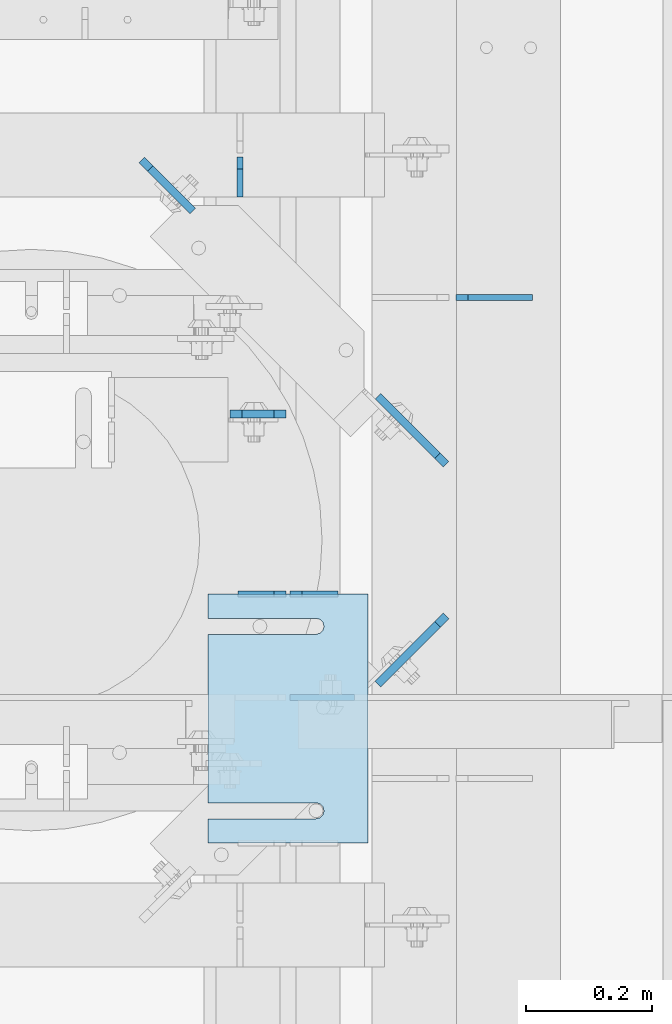
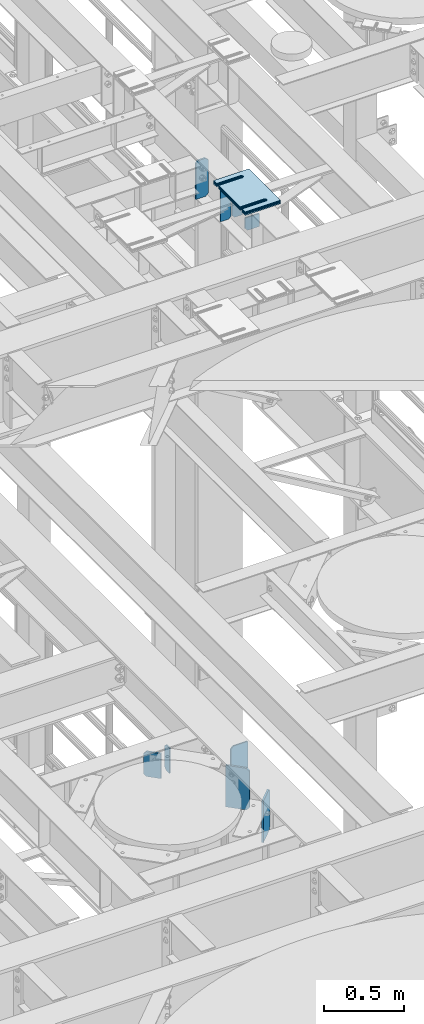
# One storey, part 1639 of 1876: 15 plates, 9 elements without a shape of their own.
"""IFC2X3 building model written with IfcOpenShell, lengths in millimetres."""

from ifc_helpers import new_model, si_unit, frame, origin_with_axes, place, context, subcontext, project, spatial, faceted_brep, material, type_object, element, aggregate, save


model = new_model("IFC2X3")

# Units and contexts
model_context = context("Model", 3, precision=1e-05, world=origin_with_axes())
body_context = subcontext(model_context, "Body", "Model", "MODEL_VIEW")
ifc_project = project(units=[si_unit("LENGTHUNIT", "METRE", prefix="MILLI"), si_unit("AREAUNIT", "SQUARE_METRE"), si_unit("VOLUMEUNIT", "CUBIC_METRE"), si_unit("MASSUNIT", "GRAM", prefix="KILO"), si_unit("TIMEUNIT", "SECOND"), si_unit("PLANEANGLEUNIT", "RADIAN"), si_unit("SOLIDANGLEUNIT", "STERADIAN"), si_unit("THERMODYNAMICTEMPERATUREUNIT", "DEGREE_CELSIUS"), si_unit("LUMINOUSINTENSITYUNIT", "LUMEN")], contexts=[model_context])

# Site, building, storey
site_placement = place(None, origin_with_axes())
site = spatial("IfcSite", under=ifc_project, at=site_placement, CompositionType="ELEMENT")
building_placement = place(site_placement, origin_with_axes())
building = spatial("IfcBuilding", under=site, at=building_placement, Name="Undefined", CompositionType="ELEMENT")
storey_placement = place(building_placement, origin_with_axes())
storey = spatial("IfcBuildingStorey", under=building, at=storey_placement, Name="Undefined", CompositionType="ELEMENT", Elevation=0.0)

# Assembly, plates
assembly_1_placement = place(storey_placement, origin_with_axes())
assembly_1 = element("IfcElementAssembly", 1, at=assembly_1_placement, inside=storey, Name="BEAM", AssemblyPlace="NOTDEFINED", PredefinedType="RIGID_FRAME")
ifc_material = material(Name="STEEL/A36")
plate_type_1 = type_object("IfcPlateType", PredefinedType="NOTDEFINED")
plate_1_placement = place(assembly_1_placement, frame((4905.375, 2355.85161899327, 17681.575), z_axis=(0.0, 0.0, 1.0), x_axis=(-1.0, 0.0, 0.0)))
plate_1 = element("IfcPlate", 2, at=plate_1_placement, type_object=plate_type_1, material=ifc_material, Name="PLATE", context=body_context, shape_type="Brep", body=[
    faceted_brep([(0.0, -4.76249999999982, 0.0), (0.0, -4.76249999999982, 292.100006103516), (0.0, 4.76249999999982, 292.100006103516), (0.0, 4.76249999999982, 0.0), (57.1499977111816, -4.76249999999982, 292.100006103516), (57.1499977111816, 4.76249999999982, 292.100006103516), (76.1999969482422, -4.76249999999982, 273.050006866455), (76.1999969482422, 4.76249999999982, 273.050006866455), (76.1999969482422, -4.76249999999982, 19.0499992370605), (76.1999969482422, 4.76249999999982, 19.0499992370605), (57.1499977111816, -4.76249999999982, 0.0), (57.1499977111816, 4.76249999999982, 0.0)], [[[0, 1, 2, 3]], [[1, 4, 5, 2]], [[4, 6, 7, 5]], [[6, 8, 9, 7]], [[8, 10, 11, 9]], [[10, 0, 3, 11]], [[5, 7, 9, 11, 3, 2]], [[10, 8, 6, 4, 1, 0]]]),
])
plate_2_placement = place(assembly_1_placement, frame((4822.825, 2355.85161899327, 17681.575), z_axis=(0.0, 0.0, 1.0), x_axis=(-1.0, 0.0, 0.0)))
plate_2 = element("IfcPlate", 3, at=plate_2_placement, type_object=plate_type_1, material=ifc_material, Name="PLATE", context=body_context, shape_type="Brep", body=[
    faceted_brep([(0.0, -4.76249999999982, 19.0499992370605), (0.0, -4.76249999999982, 273.050006866455), (0.0, 4.76249999999982, 273.050006866455), (0.0, 4.76249999999982, 19.0499992370605), (19.0499992370605, -4.76249999999982, 292.100006103516), (19.0499992370605, 4.76249999999982, 292.100006103516), (76.1999969482422, -4.76249999999982, 292.100006103516), (76.1999969482422, 4.76249999999982, 292.100006103516), (76.1999969482422, -4.76250000000073, 0.0), (76.1999969482422, 4.76250000000073, 0.0), (19.0499992370605, -4.76249999999982, 0.0), (19.0499992370605, 4.76249999999982, 0.0)], [[[0, 1, 2, 3]], [[1, 4, 5, 2]], [[4, 6, 7, 5]], [[6, 8, 9, 7]], [[8, 10, 11, 9]], [[10, 0, 3, 11]], [[5, 7, 9, 11, 3, 2]], [[10, 8, 6, 4, 1, 0]]]),
])

# Assembly, plate
assembly_2_placement = place(storey_placement, origin_with_axes())
assembly_2 = element("IfcElementAssembly", 4, at=assembly_2_placement, inside=storey, Name="BEAM", AssemblyPlace="NOTDEFINED", PredefinedType="RIGID_FRAME")
plate_type_2 = type_object("IfcPlateType", PredefinedType="NOTDEFINED")
plate_3_placement = place(assembly_2_placement, frame((4749.8, 2984.5, 13111.1625), z_axis=(0.0, 0.0, 1.0), x_axis=(0.0, 1.0, 0.0)))
plate_3 = element("IfcPlate", 5, at=plate_3_placement, type_object=plate_type_2, material=ifc_material, Name="PLATE", context=body_context, shape_type="Brep", body=[
    faceted_brep([(0.0, -4.76249999999982, 0.0), (0.0, -4.76249999999982, 190.5), (0.0, 4.76249999999982, 190.5), (0.0, 4.76249999999982, 0.0), (44.4500007629395, -4.76249999999982, 190.5), (44.4500007629395, 4.76249999999982, 190.5), (63.5, -4.76249999999982, 171.450000762939), (63.5, 4.76249999999982, 171.450000762939), (63.5, -4.76249999999982, 19.0499992370605), (63.5, 4.76249999999982, 19.0499992370605), (44.4500007629395, -4.76249999999982, 0.0), (44.4500007629395, 4.76249999999982, 0.0)], [[[0, 1, 2, 3]], [[1, 4, 5, 2]], [[4, 6, 7, 5]], [[6, 8, 9, 7]], [[8, 10, 11, 9]], [[10, 0, 3, 11]], [[5, 7, 9, 11, 3, 2]], [[10, 8, 6, 4, 1, 0]]]),
])

# Plate
plate_type_3 = type_object("IfcPlateType", PredefinedType="NOTDEFINED")
plate_4_placement = place(assembly_1_placement, frame((4829.17444174189, 2192.33987259546, 17780.0934066252), z_axis=(1.0, 0.0, 0.0), x_axis=(0.0, 0.0, -1.0)))
plate_4 = element("IfcPlate", 6, at=plate_4_placement, type_object=plate_type_3, material=ifc_material, Name="PLATE", context=body_context, shape_type="Brep", body=[
    faceted_brep([(0.0, -4.76249999999982, 0.0), (0.0, -4.76250000001255, 102.325820922852), (0.0, 4.76249999998754, 102.325820922853), (0.0, 4.76249999999982, 0.0), (98.5184097290039, -4.76250000001255, 102.325820922852), (98.5184097290039, 4.76249999998754, 102.325820922853), (98.5184097290039, -4.76250000000164, 19.0499992370587), (98.5184097290039, 4.76249999999845, 19.0499992370605), (79.4684104919434, -4.76249999999936, -9.09494701772928e-13), (79.4684104919434, 4.76250000000027, 0.0)], [[[0, 1, 2, 3]], [[1, 4, 5, 2]], [[4, 6, 7, 5]], [[6, 8, 9, 7]], [[8, 0, 3, 9]], [[5, 7, 9, 3, 2]], [[8, 6, 4, 1, 0]]]),
])

plate_type_4 = type_object("IfcPlateType", PredefinedType="NOTDEFINED")
plate_5_placement = place(assembly_1_placement, frame((4822.825, 2641.59941415787, 17683.1625), z_axis=(0.0, 0.0, 1.0), x_axis=(-1.0, 0.0, 0.0)))
plate_5 = element("IfcPlate", 7, at=plate_5_placement, type_object=plate_type_4, material=ifc_material, Name="PLATE", context=body_context, shape_type="Brep", body=[
    faceted_brep([(0.0, -6.35000000000196, 19.0499992370605), (0.0, -6.35000000000036, 271.462512969971), (0.0, 6.35000000000036, 271.462512969971), (0.0, 6.35000000000105, 19.0499992370605), (19.0499992370605, -6.35000000000036, 290.512512207031), (19.0499992370605, 6.35000000000036, 290.512512207031), (69.8500003814697, -6.34999999999991, 290.512512207031), (69.8500003814697, 6.34999999999991, 290.512512207031), (88.9000015258789, -6.35000000000036, 271.462512969971), (88.9000015258789, 6.35000000000036, 271.462512969971), (88.9000015258789, -6.34999999999991, 0.0), (88.9000015258789, 6.34999999999991, 0.0), (19.0499992370642, -6.35000000000105, 0.0), (19.0499992370633, 6.35000000000105, 0.0)], [[[0, 1, 2, 3]], [[1, 4, 5, 2]], [[4, 6, 7, 5]], [[6, 8, 9, 7]], [[8, 10, 11, 9]], [[10, 12, 13, 11]], [[12, 0, 3, 13]], [[5, 7, 9, 11, 13, 3, 2]], [[12, 10, 8, 6, 4, 1, 0]]]),
])

aggregate(assembly_1, [plate_1, plate_2, plate_4, plate_5])

# Assembly, plate
assembly_3_placement = place(storey_placement, origin_with_axes())
assembly_3 = element("IfcElementAssembly", 8, at=assembly_3_placement, inside=storey, Name="SHIM PLATE", AssemblyPlace="NOTDEFINED", PredefinedType="RIGID_FRAME")
plate_type_5 = type_object("IfcPlateType", PredefinedType="NOTDEFINED")
plate_6_placement = place(assembly_3_placement, frame((4952.99891175895, 1962.15311651737, 18007.0115), z_axis=(-1.0, 0.0, 0.0), x_axis=(0.0, 1.0, 0.0)))
plate_6 = element("IfcPlate", 9, at=plate_6_placement, type_object=plate_type_5, material=ifc_material, Name="SHIM PLATE", context=body_context, shape_type="Brep", body=[
    faceted_brep([(38.0954210666328, -1.58750000000146, 253.999557495103), (38.0976431969724, -1.58750000000146, 82.6182312417654), (38.0976431969724, 1.58750000000146, 82.6182312417654), (38.0954210666328, 1.58750000000146, 253.999557495103), (39.7991131045027, -1.58750000000146, 76.2682279470096), (39.7991131045027, 1.58750000000146, 76.2682279470096), (44.4476316136985, -1.58750000000146, 71.6196994315187), (44.4476316136985, 1.58750000000146, 71.6196994315187), (50.7976312458977, -1.58750000000146, 69.9182158551362), (50.7976312458977, 1.58750000000146, 69.9182158551362), (57.1476337740625, -1.58750000000146, 71.6196886236189), (57.1476337740625, 1.58750000000146, 71.6196886236189), (61.7961601951824, -1.58750000000146, 76.2682092271793), (61.7961601951824, 1.58750000000146, 76.2682092271793), (63.497640910601, -1.58750000000146, 82.6182096259718), (63.497640910601, 1.58750000000146, 82.6182096259718), (63.4954187799489, -1.58750000000146, 253.999557267866), (63.4954187799489, 1.58750000000146, 253.999557495093), (9.09494701772928e-13, -1.58750000000146, 4.54747350886464e-13), (1.89071320164658e-05, -1.58750000000146, 253.999557495117), (1.89071320164658e-05, 1.58750000000146, 253.999557495117), (9.09494701772928e-13, 1.58750000000146, 4.54747350886464e-13), (393.698486328125, -1.58750000000146, -1.40062184073031e-10), (393.698486328125, 1.58750000000146, -1.40062184073031e-10), (393.698516845714, -1.58750000000146, 253.999557494967), (393.698516845714, 1.58750000000146, 253.999557494967), (355.593905292273, 1.58750000000146, 253.999557494981), (355.593905292273, -1.58750000000146, 253.999558194833), (355.596127251301, 1.58750000000146, 82.6182258117283), (355.596127251301, -1.58750000000146, 82.6182258117283), (353.894652887411, 1.58750000000146, 76.2682211679371), (353.894652887411, -1.58750000000146, 76.2682211679371), (349.246128913514, 1.58750000000146, 71.6196946431969), (349.246128913514, -1.58750000000146, 71.6196946431969), (342.896125203397, 1.58750000000146, 69.9182167947934), (342.896125203397, -1.58750000000146, 69.9182167947934), (336.546122348359, 1.58750000000146, 71.6196978343955), (336.546122348359, -1.58750000000146, 71.6196978343955), (331.897600710579, 1.58750000000146, 76.2682266952543), (331.897600710579, -1.58750000000146, 76.2682266952543), (330.196129537885, 1.58750000000146, 82.6182321941214), (330.196129537885, -1.58750000000146, 82.6182321941214), (330.193907578964, -1.58750000000146, 253.999557494991), (330.193907578964, 1.58750000000146, 253.999557494991)], [[[0, 1, 2, 3]], [[4, 5, 2, 1]], [[6, 7, 5, 4]], [[8, 9, 7, 6]], [[10, 11, 9, 8]], [[12, 13, 11, 10]], [[14, 15, 13, 12]], [[16, 17, 15, 14]], [[18, 19, 20, 21]], [[22, 18, 21, 23]], [[24, 22, 23, 25]], [[24, 25, 26, 27]], [[27, 26, 28, 29]], [[29, 28, 30, 31]], [[31, 30, 32, 33]], [[33, 32, 34, 35]], [[35, 34, 36, 37]], [[37, 36, 38, 39]], [[39, 38, 40, 41]], [[42, 41, 40, 43]], [[12, 10, 8, 6, 4, 1, 0, 19, 18, 22, 24, 27, 29, 31, 33, 35, 37, 39, 41, 42, 16, 14]], [[20, 19, 0, 3]], [[43, 40, 38, 36, 34, 32, 30, 28, 26, 25, 23, 21, 20, 3, 2, 5, 7, 9, 11, 13, 15, 17]], [[42, 43, 17, 16]]]),
])
aggregate(assembly_3, [plate_6])

assembly_4_placement = place(storey_placement, origin_with_axes())
assembly_4 = element("IfcElementAssembly", 10, at=assembly_4_placement, inside=storey, Name="SHIM PLATE", AssemblyPlace="NOTDEFINED", PredefinedType="RIGID_FRAME")
plate_7_placement = place(assembly_4_placement, frame((4952.99891175913, 1962.15311651737, 18003.8365), z_axis=(-1.0, 0.0, 0.0), x_axis=(0.0, 1.0, 0.0)))
plate_7 = element("IfcPlate", 11, at=plate_7_placement, type_object=plate_type_5, material=ifc_material, Name="SHIM PLATE", context=body_context, shape_type="Brep", body=[
    faceted_brep([(38.0954210666328, -1.58750000000146, 253.999557495103), (38.0976431969724, -1.58750000000146, 82.6182312417654), (38.0976431969724, 1.58750000000146, 82.6182312417654), (38.0954210666328, 1.58750000000146, 253.999557495103), (39.7991131045027, -1.58750000000146, 76.2682279470096), (39.7991131045027, 1.58750000000146, 76.2682279470096), (44.4476316136985, -1.58750000000146, 71.6196994315187), (44.4476316136985, 1.58750000000146, 71.6196994315187), (50.7976312458977, -1.58750000000146, 69.9182158551362), (50.7976312458977, 1.58750000000146, 69.9182158551362), (57.1476337740625, -1.58750000000146, 71.6196886236189), (57.1476337740625, 1.58750000000146, 71.6196886236189), (61.7961601951824, -1.58750000000146, 76.2682092271793), (61.7961601951824, 1.58750000000146, 76.2682092271793), (63.497640910601, -1.58750000000146, 82.6182096259718), (63.497640910601, 1.58750000000146, 82.6182096259718), (63.4954187799489, -1.58750000000146, 253.999557267866), (63.4954187799489, 1.58750000000146, 253.999557495093), (9.09494701772928e-13, -1.58750000000146, 4.54747350886464e-13), (1.89071320164658e-05, -1.58750000000146, 253.999557495117), (1.89071320164658e-05, 1.58750000000146, 253.999557495117), (9.09494701772928e-13, 1.58750000000146, 4.54747350886464e-13), (393.698486328125, -1.58750000000146, -1.40062184073031e-10), (393.698486328125, 1.58750000000146, -1.40062184073031e-10), (393.698516845714, -1.58750000000146, 253.999557494967), (393.698516845714, 1.58750000000146, 253.999557494967), (355.593905292273, 1.58750000000146, 253.999557494981), (355.593905292273, -1.58750000000146, 253.999558194833), (355.596127251301, 1.58750000000146, 82.6182258117283), (355.596127251301, -1.58750000000146, 82.6182258117283), (353.894652887411, 1.58750000000146, 76.2682211679371), (353.894652887411, -1.58750000000146, 76.2682211679371), (349.246128913514, 1.58750000000146, 71.6196946431969), (349.246128913514, -1.58750000000146, 71.6196946431969), (342.896125203397, 1.58750000000146, 69.9182167947934), (342.896125203397, -1.58750000000146, 69.9182167947934), (336.546122348359, 1.58750000000146, 71.6196978343955), (336.546122348359, -1.58750000000146, 71.6196978343955), (331.897600710579, 1.58750000000146, 76.2682266952543), (331.897600710579, -1.58750000000146, 76.2682266952543), (330.196129537885, 1.58750000000146, 82.6182321941214), (330.196129537885, -1.58750000000146, 82.6182321941214), (330.193907578964, -1.58750000000146, 253.999557494991), (330.193907578964, 1.58750000000146, 253.999557494991)], [[[0, 1, 2, 3]], [[4, 5, 2, 1]], [[6, 7, 5, 4]], [[8, 9, 7, 6]], [[10, 11, 9, 8]], [[12, 13, 11, 10]], [[14, 15, 13, 12]], [[16, 17, 15, 14]], [[18, 19, 20, 21]], [[22, 18, 21, 23]], [[24, 22, 23, 25]], [[24, 25, 26, 27]], [[27, 26, 28, 29]], [[29, 28, 30, 31]], [[31, 30, 32, 33]], [[33, 32, 34, 35]], [[35, 34, 36, 37]], [[37, 36, 38, 39]], [[39, 38, 40, 41]], [[42, 41, 40, 43]], [[12, 10, 8, 6, 4, 1, 0, 19, 18, 22, 24, 27, 29, 31, 33, 35, 37, 39, 41, 42, 16, 14]], [[20, 19, 0, 3]], [[43, 40, 38, 36, 34, 32, 30, 28, 26, 25, 23, 21, 20, 3, 2, 5, 7, 9, 11, 13, 15, 17]], [[42, 43, 17, 16]]]),
])
aggregate(assembly_4, [plate_7])

assembly_5_placement = place(storey_placement, origin_with_axes())
assembly_5 = element("IfcElementAssembly", 12, at=assembly_5_placement, inside=storey, Name="SHIM PLATE", AssemblyPlace="NOTDEFINED", PredefinedType="RIGID_FRAME")
plate_type_6 = type_object("IfcPlateType", PredefinedType="NOTDEFINED")
plate_8_placement = place(assembly_5_placement, frame((4952.99891175877, 1962.15311651737, 18009.3925), z_axis=(-1.0, 0.0, 0.0), x_axis=(0.0, 1.0, 0.0)))
plate_8 = element("IfcPlate", 13, at=plate_8_placement, type_object=plate_type_6, material=ifc_material, Name="SHIM PLATE", context=body_context, shape_type="Brep", body=[
    faceted_brep([(38.0954210666328, -0.793499999999767, 253.999557495103), (38.0976431969724, -0.793499999999767, 82.6182312417654), (38.0976431969724, 0.793499999999767, 82.6182312417654), (38.0954210666328, 0.793499999999767, 253.999557495103), (39.7991131045027, -0.793499999999767, 76.2682279470096), (39.7991131045027, 0.793499999999767, 76.2682279470096), (44.4476316136985, -0.793499999999767, 71.6196994315187), (44.4476316136985, 0.793499999999767, 71.6196994315187), (50.7976312458977, -0.793499999999767, 69.9182158551362), (50.7976312458977, 0.793499999999767, 69.9182158551362), (57.1476337740625, -0.793499999999767, 71.6196886236189), (57.1476337740625, 0.793499999999767, 71.6196886236189), (61.7961601951824, -0.793499999999767, 76.2682092271793), (61.7961601951824, 0.793499999999767, 76.2682092271793), (63.497640910601, -0.793499999999767, 82.6182096259718), (63.497640910601, 0.793499999999767, 82.6182096259718), (63.4954187799489, -0.793499999999767, 253.999557267866), (63.4954187799489, 0.793499999999767, 253.999557495093), (9.09494701772928e-13, -0.793499999999767, 0.0), (1.89070156011439e-05, -0.793499999999767, 253.999557495117), (1.89070156011439e-05, 0.793499999999767, 253.999557495117), (9.09494701772928e-13, 0.793499999999767, 0.0), (393.698486328125, -0.793499999999767, -1.39152689371258e-10), (393.698486328125, 0.793499999999767, -1.39152689371258e-10), (393.698516845714, -0.793499999999767, 253.999557494967), (393.698516845714, 0.793499999999767, 253.999557494967), (355.593905292273, 0.793499999999767, 253.999557494981), (355.593905292273, -0.793499999999767, 253.999558194833), (355.596127251301, 0.793499999999767, 82.6182258117283), (355.596127251301, -0.793499999999767, 82.6182258117283), (353.894652887411, 0.793499999999767, 76.2682211679371), (353.894652887411, -0.793499999999767, 76.2682211679371), (349.246128913514, 0.793499999999767, 71.6196946431969), (349.246128913514, -0.793499999999767, 71.6196946431969), (342.896125203397, 0.793499999999767, 69.9182167947934), (342.896125203397, -0.793499999999767, 69.9182167947934), (336.546122348359, 0.793499999999767, 71.6196978343955), (336.546122348359, -0.793499999999767, 71.6196978343955), (331.897600710579, 0.793499999999767, 76.2682266952543), (331.897600710579, -0.793499999999767, 76.2682266952543), (330.196129537885, 0.793499999999767, 82.6182321941214), (330.196129537885, -0.793499999999767, 82.6182321941214), (330.193907578964, -0.793499999999767, 253.999557494991), (330.193907578964, 0.793499999999767, 253.999557494991)], [[[0, 1, 2, 3]], [[4, 5, 2, 1]], [[6, 7, 5, 4]], [[8, 9, 7, 6]], [[10, 11, 9, 8]], [[12, 13, 11, 10]], [[14, 15, 13, 12]], [[16, 17, 15, 14]], [[18, 19, 20, 21]], [[22, 18, 21, 23]], [[24, 22, 23, 25]], [[24, 25, 26, 27]], [[27, 26, 28, 29]], [[29, 28, 30, 31]], [[31, 30, 32, 33]], [[33, 32, 34, 35]], [[35, 34, 36, 37]], [[37, 36, 38, 39]], [[39, 38, 40, 41]], [[42, 41, 40, 43]], [[12, 10, 8, 6, 4, 1, 0, 19, 18, 22, 24, 27, 29, 31, 33, 35, 37, 39, 41, 42, 16, 14]], [[20, 19, 0, 3]], [[43, 40, 38, 36, 34, 32, 30, 28, 26, 25, 23, 21, 20, 3, 2, 5, 7, 9, 11, 13, 15, 17]], [[42, 43, 17, 16]]]),
])
aggregate(assembly_5, [plate_8])

assembly_6_placement = place(storey_placement, origin_with_axes())
assembly_6 = element("IfcElementAssembly", 14, at=assembly_6_placement, inside=storey, Name="SHIM PLATE", AssemblyPlace="NOTDEFINED", PredefinedType="RIGID_FRAME")
plate_type_7 = type_object("IfcPlateType", PredefinedType="NOTDEFINED")
plate_9_placement = place(assembly_6_placement, frame((4952.9989117593, 1962.15311651737, 17999.868), z_axis=(-1.0, 0.0, 0.0), x_axis=(0.0, 1.0, 0.0)))
plate_9 = element("IfcPlate", 15, at=plate_9_placement, type_object=plate_type_7, material=ifc_material, Name="SHIM PLATE", context=body_context, shape_type="Brep", body=[
    faceted_brep([(38.0954210666329, -2.38100000000122, 253.999557495103), (38.0976431969724, -2.38100000000122, 82.6182312417654), (38.0976431969724, 2.38100000000122, 82.6182312417654), (38.0954210666329, 2.38100000000122, 253.999557495103), (39.7991131045027, -2.38100000000122, 76.2682279470096), (39.7991131045027, 2.38100000000122, 76.2682279470096), (44.4476316136985, -2.38100000000122, 71.6196994315187), (44.4476316136985, 2.38100000000122, 71.6196994315187), (50.7976312458977, -2.38100000000122, 69.9182158551362), (50.7976312458977, 2.38100000000122, 69.9182158551362), (57.1476337740625, -2.38100000000122, 71.6196886236189), (57.1476337740625, 2.38100000000122, 71.6196886236189), (61.7961601951824, -2.38100000000122, 76.2682092271793), (61.7961601951824, 2.38100000000122, 76.2682092271793), (63.497640910601, -2.38100000000122, 82.6182096259718), (63.497640910601, 2.38100000000122, 82.6182096259718), (63.4954187799489, -2.38100000000122, 253.999557267866), (63.4954187799489, 2.38100000000122, 253.999557495093), (0.0, -2.38100000000122, 4.54747350886464e-13), (1.89072484317876e-05, -2.38100000000122, 253.999557495117), (1.89072484317876e-05, 2.38100000000122, 253.999557495117), (0.0, 2.38100000000122, 4.54747350886464e-13), (393.698486328125, -2.38100000000122, -1.40971678774804e-10), (393.698486328125, 2.38100000000122, -1.40971678774804e-10), (393.698516845714, -2.38100000000122, 253.999557494967), (393.698516845714, 2.38100000000122, 253.999557494967), (355.593905292273, 2.38100000000122, 253.999557494981), (355.593905292273, -2.38100000000122, 253.999558194833), (355.596127251301, 2.38100000000122, 82.6182258117283), (355.596127251301, -2.38100000000122, 82.6182258117283), (353.894652887411, 2.38100000000122, 76.2682211679371), (353.894652887411, -2.38100000000122, 76.2682211679371), (349.246128913514, 2.38100000000122, 71.6196946431969), (349.246128913514, -2.38100000000122, 71.6196946431969), (342.896125203397, 2.38100000000122, 69.9182167947934), (342.896125203397, -2.38100000000122, 69.9182167947934), (336.546122348359, 2.38100000000122, 71.6196978343955), (336.546122348359, -2.38100000000122, 71.6196978343955), (331.897600710579, 2.38100000000122, 76.2682266952543), (331.897600710579, -2.38100000000122, 76.2682266952543), (330.196129537885, 2.38100000000122, 82.6182321941214), (330.196129537885, -2.38100000000122, 82.6182321941214), (330.193907578964, -2.38100000000122, 253.999557494991), (330.193907578964, 2.38100000000122, 253.999557494991)], [[[0, 1, 2, 3]], [[4, 5, 2, 1]], [[6, 7, 5, 4]], [[8, 9, 7, 6]], [[10, 11, 9, 8]], [[12, 13, 11, 10]], [[14, 15, 13, 12]], [[16, 17, 15, 14]], [[18, 19, 20, 21]], [[22, 18, 21, 23]], [[24, 22, 23, 25]], [[24, 25, 26, 27]], [[27, 26, 28, 29]], [[29, 28, 30, 31]], [[31, 30, 32, 33]], [[33, 32, 34, 35]], [[35, 34, 36, 37]], [[37, 36, 38, 39]], [[39, 38, 40, 41]], [[42, 41, 40, 43]], [[12, 10, 8, 6, 4, 1, 0, 19, 18, 22, 24, 27, 29, 31, 33, 35, 37, 39, 41, 42, 16, 14]], [[20, 19, 0, 3]], [[43, 40, 38, 36, 34, 32, 30, 28, 26, 25, 23, 21, 20, 3, 2, 5, 7, 9, 11, 13, 15, 17]], [[42, 43, 17, 16]]]),
])
aggregate(assembly_6, [plate_9])

assembly_7_placement = place(storey_placement, origin_with_axes())
assembly_7 = element("IfcElementAssembly", 16, at=assembly_7_placement, inside=storey, Name="SHIM PLATE", AssemblyPlace="NOTDEFINED", PredefinedType="RIGID_FRAME")
plate_10_placement = place(assembly_7_placement, frame((4952.99891175948, 1962.15311651737, 17995.106), z_axis=(-1.0, 0.0, 0.0), x_axis=(0.0, 1.0, 0.0)))
plate_10 = element("IfcPlate", 17, at=plate_10_placement, type_object=plate_type_7, material=ifc_material, Name="SHIM PLATE", context=body_context, shape_type="Brep", body=[
    faceted_brep([(38.0954210666329, -2.38100000000122, 253.999557495103), (38.0976431969724, -2.38100000000122, 82.6182312417654), (38.0976431969724, 2.38100000000122, 82.6182312417654), (38.0954210666329, 2.38100000000122, 253.999557495103), (39.7991131045027, -2.38100000000122, 76.2682279470096), (39.7991131045027, 2.38100000000122, 76.2682279470096), (44.4476316136985, -2.38100000000122, 71.6196994315187), (44.4476316136985, 2.38100000000122, 71.6196994315187), (50.7976312458977, -2.38100000000122, 69.9182158551362), (50.7976312458977, 2.38100000000122, 69.9182158551362), (57.1476337740625, -2.38100000000122, 71.6196886236189), (57.1476337740625, 2.38100000000122, 71.6196886236189), (61.7961601951824, -2.38100000000122, 76.2682092271793), (61.7961601951824, 2.38100000000122, 76.2682092271793), (63.497640910601, -2.38100000000122, 82.6182096259718), (63.497640910601, 2.38100000000122, 82.6182096259718), (63.4954187799489, -2.38100000000122, 253.999557267866), (63.4954187799489, 2.38100000000122, 253.999557495093), (0.0, -2.38100000000122, 4.54747350886464e-13), (1.89072484317876e-05, -2.38100000000122, 253.999557495117), (1.89072484317876e-05, 2.38100000000122, 253.999557495117), (0.0, 2.38100000000122, 4.54747350886464e-13), (393.698486328125, -2.38100000000122, -1.40971678774804e-10), (393.698486328125, 2.38100000000122, -1.40971678774804e-10), (393.698516845714, -2.38100000000122, 253.999557494967), (393.698516845714, 2.38100000000122, 253.999557494967), (355.593905292273, 2.38100000000122, 253.999557494981), (355.593905292273, -2.38100000000122, 253.999558194833), (355.596127251301, 2.38100000000122, 82.6182258117283), (355.596127251301, -2.38100000000122, 82.6182258117283), (353.894652887411, 2.38100000000122, 76.2682211679371), (353.894652887411, -2.38100000000122, 76.2682211679371), (349.246128913514, 2.38100000000122, 71.6196946431969), (349.246128913514, -2.38100000000122, 71.6196946431969), (342.896125203397, 2.38100000000122, 69.9182167947934), (342.896125203397, -2.38100000000122, 69.9182167947934), (336.546122348359, 2.38100000000122, 71.6196978343955), (336.546122348359, -2.38100000000122, 71.6196978343955), (331.897600710579, 2.38100000000122, 76.2682266952543), (331.897600710579, -2.38100000000122, 76.2682266952543), (330.196129537885, 2.38100000000122, 82.6182321941214), (330.196129537885, -2.38100000000122, 82.6182321941214), (330.193907578964, -2.38100000000122, 253.999557494991), (330.193907578964, 2.38100000000122, 253.999557494991)], [[[0, 1, 2, 3]], [[4, 5, 2, 1]], [[6, 7, 5, 4]], [[8, 9, 7, 6]], [[10, 11, 9, 8]], [[12, 13, 11, 10]], [[14, 15, 13, 12]], [[16, 17, 15, 14]], [[18, 19, 20, 21]], [[22, 18, 21, 23]], [[24, 22, 23, 25]], [[24, 25, 26, 27]], [[27, 26, 28, 29]], [[29, 28, 30, 31]], [[31, 30, 32, 33]], [[33, 32, 34, 35]], [[35, 34, 36, 37]], [[37, 36, 38, 39]], [[39, 38, 40, 41]], [[42, 41, 40, 43]], [[12, 10, 8, 6, 4, 1, 0, 19, 18, 22, 24, 27, 29, 31, 33, 35, 37, 39, 41, 42, 16, 14]], [[20, 19, 0, 3]], [[43, 40, 38, 36, 34, 32, 30, 28, 26, 25, 23, 21, 20, 3, 2, 5, 7, 9, 11, 13, 15, 17]], [[42, 43, 17, 16]]]),
])
aggregate(assembly_7, [plate_10])

assembly_8_placement = place(storey_placement, origin_with_axes())
assembly_8 = element("IfcElementAssembly", 18, at=assembly_8_placement, inside=storey, Name="SHIM PLATE", AssemblyPlace="NOTDEFINED", PredefinedType="RIGID_FRAME")
plate_type_8 = type_object("IfcPlateType", PredefinedType="NOTDEFINED")
plate_11_placement = place(assembly_8_placement, frame((4952.99891175966, 1962.15311651737, 17987.9625), z_axis=(-1.0, 0.0, 0.0), x_axis=(0.0, 1.0, 0.0)))
plate_11 = element("IfcPlate", 19, at=plate_11_placement, type_object=plate_type_8, material=ifc_material, Name="SHIM PLATE", context=body_context, shape_type="Brep", body=[
    faceted_brep([(38.0954210666328, -4.76250000000073, 253.999557495103), (38.0976431969724, -4.76250000000073, 82.6182312417654), (38.0976431969724, 4.76250000000073, 82.6182312417654), (38.0954210666328, 4.76250000000073, 253.999557495103), (39.7991131045027, -4.76250000000073, 76.2682279470096), (39.7991131045027, 4.76250000000073, 76.2682279470096), (44.4476316136985, -4.76250000000073, 71.6196994315187), (44.4476316136985, 4.76250000000073, 71.6196994315187), (50.7976312458977, -4.76250000000073, 69.9182158551362), (50.7976312458977, 4.76250000000073, 69.9182158551362), (57.1476337740625, -4.76250000000073, 71.6196886236189), (57.1476337740625, 4.76250000000073, 71.6196886236189), (61.7961601951824, -4.76250000000073, 76.2682092271793), (61.7961601951824, 4.76250000000073, 76.2682092271793), (63.497640910601, -4.76250000000073, 82.6182096259718), (63.497640910601, 4.76250000000073, 82.6182096259718), (63.4954187799489, -4.76250000000073, 253.999557267866), (63.4954187799489, 4.76250000000073, 253.999557495093), (0.0, -4.76249999999982, 0.0), (1.89073648471094e-05, -4.76250000000073, 253.999557495117), (1.89073648471094e-05, 4.76250000000073, 253.999557495117), (0.0, 4.76249999999982, 0.0), (393.698486328125, -4.76250000000073, -1.41881173476577e-10), (393.698486328125, 4.76250000000073, -1.41881173476577e-10), (393.698516845714, -4.76250000000073, 253.999557494967), (393.698516845714, 4.76250000000073, 253.999557494967), (355.593905292273, 4.76250000000073, 253.999557494981), (355.593905292273, -4.76250000000073, 253.999558194833), (355.596127251301, 4.76250000000073, 82.6182258117283), (355.596127251301, -4.76250000000073, 82.6182258117283), (353.894652887411, 4.76250000000073, 76.2682211679371), (353.894652887411, -4.76250000000073, 76.2682211679371), (349.246128913514, 4.76250000000073, 71.6196946431969), (349.246128913514, -4.76250000000073, 71.6196946431969), (342.896125203397, 4.76250000000073, 69.9182167947934), (342.896125203397, -4.76250000000073, 69.9182167947934), (336.546122348359, 4.76250000000073, 71.6196978343955), (336.546122348359, -4.76250000000073, 71.6196978343955), (331.897600710579, 4.76250000000073, 76.2682266952543), (331.897600710579, -4.76250000000073, 76.2682266952543), (330.196129537885, 4.76250000000073, 82.6182321941214), (330.196129537885, -4.76250000000073, 82.6182321941214), (330.193907578964, -4.76250000000073, 253.999557494991), (330.193907578964, 4.76250000000073, 253.999557494991)], [[[0, 1, 2, 3]], [[4, 5, 2, 1]], [[6, 7, 5, 4]], [[8, 9, 7, 6]], [[10, 11, 9, 8]], [[12, 13, 11, 10]], [[14, 15, 13, 12]], [[16, 17, 15, 14]], [[18, 19, 20, 21]], [[22, 18, 21, 23]], [[24, 22, 23, 25]], [[24, 25, 26, 27]], [[27, 26, 28, 29]], [[29, 28, 30, 31]], [[31, 30, 32, 33]], [[33, 32, 34, 35]], [[35, 34, 36, 37]], [[37, 36, 38, 39]], [[39, 38, 40, 41]], [[42, 41, 40, 43]], [[12, 10, 8, 6, 4, 1, 0, 19, 18, 22, 24, 27, 29, 31, 33, 35, 37, 39, 41, 42, 16, 14]], [[20, 19, 0, 3]], [[43, 40, 38, 36, 34, 32, 30, 28, 26, 25, 23, 21, 20, 3, 2, 5, 7, 9, 11, 13, 15, 17]], [[42, 43, 17, 16]]]),
])
aggregate(assembly_8, [plate_11])

# Assembly, plates
assembly_9_placement = place(storey_placement, origin_with_axes())
assembly_9 = element("IfcElementAssembly", 20, at=assembly_9_placement, inside=storey, Name="BEAM", AssemblyPlace="NOTDEFINED", PredefinedType="RIGID_FRAME")
plate_type_9 = type_object("IfcPlateType", PredefinedType="NOTDEFINED")
plate_12_placement = place(assembly_9_placement, frame((5076.30360497623, 2321.48768694688, 12974.6375), z_axis=(0.0, 0.0, 1.0), x_axis=(-0.707104099181461, -0.707109463181462, 0.0)))
plate_12 = element("IfcPlate", 21, at=plate_12_placement, type_object=plate_type_9, material=ifc_material, Name="PLATE", context=body_context, shape_type="Brep", body=[
    faceted_brep([(0.0, -6.35000000000196, 19.0499992370605), (-9.09494701772928e-13, -6.34999999999764, 296.862506866455), (1.81898940354586e-12, 6.34999999999786, 296.862506866455), (0.0, 6.35000000000105, 19.0499992370605), (19.0499992370587, -6.34999999999604, 315.912506103516), (19.0499992370624, 6.34999999999945, 315.912506103516), (152.399993896478, -6.3499999999849, 315.912506103516), (152.399993896482, 6.35000000000991, 315.912506103516), (152.399993896478, -6.3499999999849, 0.0), (152.399993896482, 6.35000000000991, 0.0), (19.0499992370642, -6.35000000000105, 0.0), (19.0499992370633, 6.35000000000105, 0.0)], [[[0, 1, 2, 3]], [[1, 4, 5, 2]], [[4, 6, 7, 5]], [[6, 8, 9, 7]], [[8, 10, 11, 9]], [[10, 0, 3, 11]], [[5, 7, 9, 11, 3, 2]], [[10, 8, 6, 4, 1, 0]]]),
])
plate_13_placement = place(assembly_9_placement, frame((5076.30360497623, 2561.66231309604, 12974.6375), z_axis=(0.0, 0.0, 1.0), x_axis=(-0.707104099181461, 0.707109463181462, 0.0)))
plate_13 = element("IfcPlate", 22, at=plate_13_placement, type_object=plate_type_9, material=ifc_material, Name="PLATE", context=body_context, shape_type="Brep", body=[
    faceted_brep([(0.0, -6.35000000000196, 19.0499992370605), (-9.09494701772928e-13, -6.34999999999764, 296.862506866455), (1.81898940354586e-12, 6.34999999999786, 296.862506866455), (0.0, 6.35000000000105, 19.0499992370605), (19.0499992370587, -6.34999999999604, 315.912506103516), (19.0499992370624, 6.34999999999945, 315.912506103516), (152.399993896478, -6.3499999999849, 315.912506103516), (152.399993896482, 6.35000000000991, 315.912506103516), (152.399993896478, -6.3499999999849, 0.0), (152.399993896482, 6.35000000000991, 0.0), (19.0499992370642, -6.35000000000105, 0.0), (19.0499992370633, 6.35000000000105, 0.0)], [[[0, 1, 2, 3]], [[1, 4, 5, 2]], [[4, 6, 7, 5]], [[6, 8, 9, 7]], [[8, 10, 11, 9]], [[10, 0, 3, 11]], [[5, 7, 9, 11, 3, 2]], [[10, 8, 6, 4, 1, 0]]]),
])

# Plate
plate_type_10 = type_object("IfcPlateType", PredefinedType="NOTDEFINED")
plate_14_placement = place(assembly_2_placement, frame((4594.45968424013, 3043.50988903763, 13112.75), z_axis=(0.0, 0.0, 1.0), x_axis=(0.707104099181461, -0.707109463181462, 0.0)))
plate_14 = element("IfcPlate", 23, at=plate_14_placement, type_object=plate_type_10, material=ifc_material, Name="PLATE", context=body_context, shape_type="Brep", body=[
    faceted_brep([(0.0, -6.35000000000196, 19.0499992370605), (0.0, -6.34999999999991, 169.862506866455), (0.0, 6.34999999999991, 169.862506866455), (0.0, 6.35000000000105, 19.0499992370605), (19.0499992370605, -6.34999999999991, 188.912506103516), (19.0499992370605, 6.34999999999991, 188.912506103516), (114.300003051752, -6.34999999998786, 188.912506103516), (114.300003051755, 6.35000000000741, 188.912506103516), (114.300003051752, -6.34999999998786, 0.0), (114.300003051755, 6.35000000000741, 0.0), (19.0499992370642, -6.35000000000105, 0.0), (19.0499992370633, 6.35000000000105, 0.0)], [[[0, 1, 2, 3]], [[1, 4, 5, 2]], [[4, 6, 7, 5]], [[6, 8, 9, 7]], [[8, 10, 11, 9]], [[10, 0, 3, 11]], [[5, 7, 9, 11, 3, 2]], [[10, 8, 6, 4, 1, 0]]]),
])

aggregate(assembly_2, [plate_14, plate_3])

plate_type_11 = type_object("IfcPlateType", PredefinedType="NOTDEFINED")
plate_15_placement = place(assembly_9_placement, frame((5213.35, 2825.75, 12973.05), z_axis=(0.0, 0.0, 1.0), x_axis=(-1.0, 0.0, 0.0)))
plate_15 = element("IfcPlate", 24, at=plate_15_placement, type_object=plate_type_11, material=ifc_material, Name="PLATE", context=body_context, shape_type="Brep", body=[
    faceted_brep([(0.0, -4.76249999999982, 0.0), (0.0, -4.76249999999982, 317.5), (0.0, 4.76249999999982, 317.5), (0.0, 4.76249999999982, 0.0), (102.393749237061, -4.76249999999982, 317.5), (102.393749237061, 4.76249999999982, 317.5), (121.443748474121, -4.76249999999982, 298.450000762939), (121.443748474121, 4.76249999999982, 298.450000762939), (121.443748474121, -4.76249999999982, 19.0499992370605), (121.443748474121, 4.76249999999982, 19.0499992370605), (102.393749237061, -4.76249999999982, 0.0), (102.393749237061, 4.76249999999982, 0.0)], [[[0, 1, 2, 3]], [[1, 4, 5, 2]], [[4, 6, 7, 5]], [[6, 8, 9, 7]], [[8, 10, 11, 9]], [[10, 0, 3, 11]], [[5, 7, 9, 11, 3, 2]], [[10, 8, 6, 4, 1, 0]]]),
])

aggregate(assembly_9, [plate_12, plate_13, plate_15])

save(model, "model.ifc")
